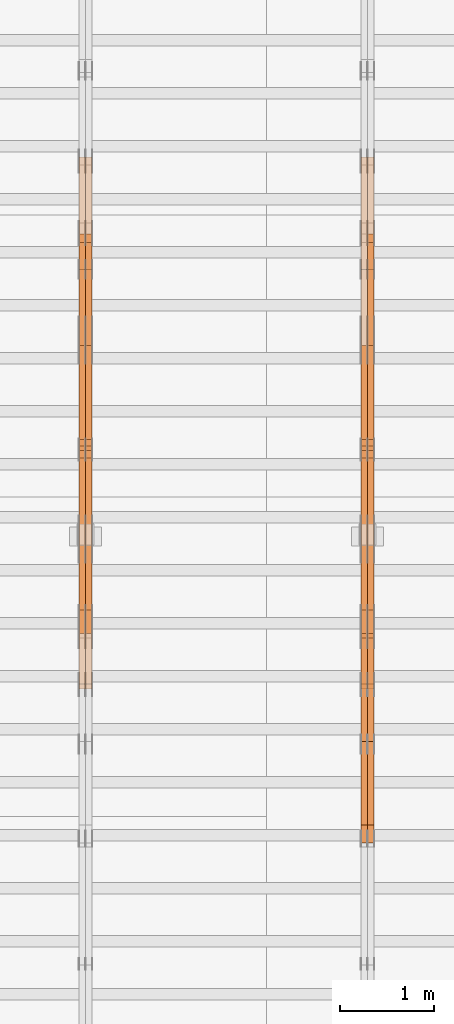
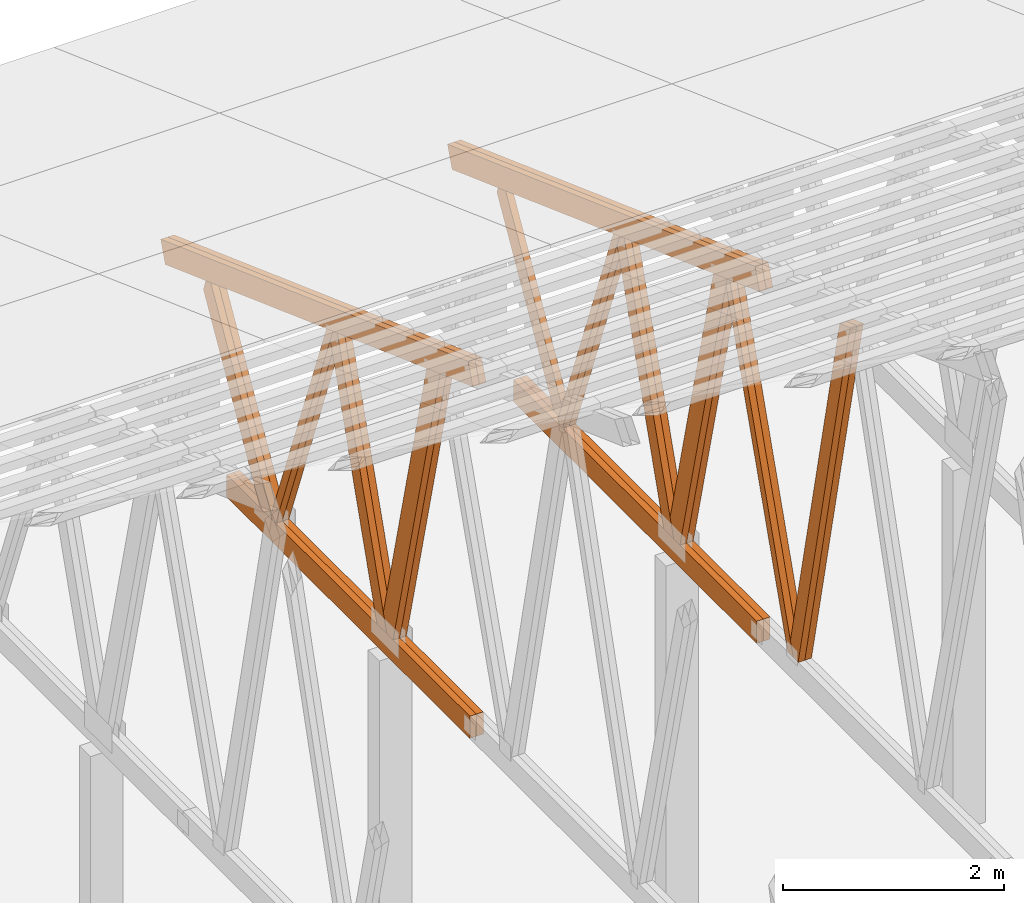
# One storey, part 58 of 189: 27 proxies.
"""IFC2X3 building model written with IfcOpenShell, lengths in millimetres."""

import ifcopenshell
import ifcopenshell.guid

model = None  # the IFC model being written
_history = None  # IfcOwnerHistory: only IFC2X3 demands one
_inside = {}  # id of a spatial element -> (the spatial element, [elements in it])
_under = {}  # id of a project, library or spatial element -> (it, [spatial elements below it])
_declared = {}  # id of a project -> (the project, [libraries it declares])
_typed = {}  # id of a type object -> (the type object, [elements of that type])
_made_of = {}  # id of a material, layer set ... -> (it, [elements and type objects made of it])


def new_model(schema):
    """Start an empty IFC model of exactly this schema.

    Asked for "IFC4X3", IfcOpenShell would pick the latest addendum, in which some entities
    have other attributes; the version numbers below select the first issue.
    IFC2X3 requires an IfcOwnerHistory on every rooted entity: one is made here for all.
    """
    global model, _history
    if schema == "IFC4X3":
        model = ifcopenshell.file(schema_version=(4, 3, 0, 0))
    else:
        model = ifcopenshell.file(schema=schema)
    _inside.clear()
    _under.clear()
    _declared.clear()
    _typed.clear()
    _made_of.clear()
    _history = None
    if model.schema == "IFC2X3":
        org = make("IfcOrganization", Name="unknown")
        user = make(
            "IfcPersonAndOrganization",
            ThePerson=make("IfcPerson", FamilyName="unknown"),
            TheOrganization=org,
        )
        app = make(
            "IfcApplication",
            ApplicationDeveloper=org,
            Version="unknown",
            ApplicationFullName="unknown",
            ApplicationIdentifier="unknown",
        )
        _history = make(
            "IfcOwnerHistory",
            OwningUser=user,
            OwningApplication=app,
            ChangeAction="ADDED",
            CreationDate=0,
        )
    return model


def make(cls, **values):
    """One entity of the class cls with the attributes given. An attribute that is None is left unset."""
    return model.create_entity(
        cls, **{name: value for name, value in values.items() if value is not None}
    )


def entity(cls, *values):
    """Any entity or typed value of the class cls, its attributes in the order of the schema. None: left unset."""
    e = model.create_entity(cls)
    for i, value in enumerate(values):
        if value is not None:
            e[i] = value
    return e


def rooted(cls, **values):
    """An entity with a GlobalId (a new one), such as an element, a storey or a relation."""
    return make(cls, GlobalId=ifcopenshell.guid.new(), OwnerHistory=_history, **values)


def si_unit(unit_type, name, prefix=None):
    """IfcSIUnit, for example si_unit("LENGTHUNIT", "METRE", prefix="MILLI")."""
    return make("IfcSIUnit", UnitType=unit_type, Prefix=prefix, Name=name)


def converted_unit(unit_type, name, factor, base, dimensions=None, offset=None):
    """IfcConversionBasedUnit, such as the inch: factor (a typed value) times the base unit."""
    return make(
        "IfcConversionBasedUnit"
        if offset is None
        else "IfcConversionBasedUnitWithOffset",
        ConversionOffset=offset,
        Dimensions=None
        if dimensions is None
        else entity("IfcDimensionalExponents", *dimensions),
        UnitType=unit_type,
        Name=name,
        ConversionFactor=make(
            "IfcMeasureWithUnit", ValueComponent=factor, UnitComponent=base
        ),
    )


def derived_unit(unit_type, elements):
    """IfcDerivedUnit: a product of units, each with its exponent."""
    return make(
        "IfcDerivedUnit",
        Elements=[
            make("IfcDerivedUnitElement", Unit=unit, Exponent=power)
            for unit, power in elements
        ],
        UnitType=unit_type,
    )


def assignment(units):
    """IfcUnitAssignment: the units of a project."""
    return None if units is None else make("IfcUnitAssignment", Units=units)


def point(xyz):
    """IfcCartesianPoint."""
    return None if xyz is None else make("IfcCartesianPoint", Coordinates=xyz)


def direction(xyz):
    """IfcDirection."""
    return None if xyz is None else make("IfcDirection", DirectionRatios=xyz)


def frame(location, z_axis=None, x_axis=None):
    """IfcAxis2Placement3D, a coordinate frame: its origin and axes. An axis left out is left unset."""
    return make(
        "IfcAxis2Placement3D",
        Location=point(location),
        Axis=direction(z_axis),
        RefDirection=direction(x_axis),
    )


def frame_2d(location, x_axis=None):
    """IfcAxis2Placement2D, a coordinate frame in the plane: its origin and x axis."""
    return make(
        "IfcAxis2Placement2D", Location=point(location), RefDirection=direction(x_axis)
    )


def origin():
    """The frame at (0, 0, 0) with its axes left unset."""
    return frame((0.0, 0.0, 0.0))


def origin_2d_with_axis():
    """The frame at (0, 0) in the plane with the x axis (1, 0) written out."""
    return frame_2d((0.0, 0.0), x_axis=(1.0, 0.0))


def place(relative_to, where):
    """IfcLocalPlacement: puts the frame where relative to a parent placement (None: the world)."""
    return make(
        "IfcLocalPlacement", PlacementRelTo=relative_to, RelativePlacement=where
    )


def context(
    kind, dimensions, precision=None, world=None, true_north=None, identifier=None
):
    """IfcGeometricRepresentationContext, for example the 3D "Model" context."""
    return make(
        "IfcGeometricRepresentationContext",
        ContextIdentifier=identifier,
        ContextType=kind,
        CoordinateSpaceDimension=dimensions,
        Precision=precision,
        WorldCoordinateSystem=world,
        TrueNorth=true_north,
    )


def subcontext(parent, identifier, kind, view, scale=None):
    """IfcGeometricRepresentationSubContext, for example "Body" below "Model"."""
    return make(
        "IfcGeometricRepresentationSubContext",
        ContextIdentifier=identifier,
        ContextType=kind,
        ParentContext=parent,
        TargetScale=scale,
        TargetView=view,
    )


def project(units=None, contexts=None):
    """IfcProject with its units and contexts."""
    return rooted(
        "IfcProject",
        Name="project",
        RepresentationContexts=contexts,
        UnitsInContext=assignment(units),
    )


def spatial(cls, under=None, at=None, **own):
    """A site, building, storey or space (cls), placed at a placement, below another one or the project."""
    s = rooted(cls, ObjectPlacement=at, **own)
    if under is not None:
        _under.setdefault(under.id(), (under, []))[1].append(s)
    return s


def polyline(points):
    """IfcPolyline through the points."""
    return make("IfcPolyline", Points=[point(p) for p in points])


def profile(cls, at=None, kind="AREA", **sizes):
    """A parametric profile (cls). Its sizes go by their IFC names, for example OverallWidth=200.0."""
    return make(cls, ProfileType=kind, Position=at, **sizes)


def rectangle(**sizes):
    """IfcRectangleProfileDef."""
    return profile("IfcRectangleProfileDef", **sizes)


def outline(outer, holes=None, kind="AREA"):
    """IfcArbitraryClosedProfileDef: a profile drawn as a closed curve; with holes, ...WithVoids."""
    if holes is None:
        return make("IfcArbitraryClosedProfileDef", ProfileType=kind, OuterCurve=outer)
    return make(
        "IfcArbitraryProfileDefWithVoids",
        ProfileType=kind,
        OuterCurve=outer,
        InnerCurves=holes,
    )


def extrude(swept, where, along, depth):
    """IfcExtrudedAreaSolid: the profile swept, set in the frame where, extruded along a direction by depth."""
    return make(
        "IfcExtrudedAreaSolid",
        SweptArea=swept,
        Position=where,
        ExtrudedDirection=direction(along),
        Depth=depth,
    )


def shape(context_of_items, identifier, shape_type, items):
    """IfcShapeRepresentation: the items that make up one representation, for example the "Body"."""
    return make(
        "IfcShapeRepresentation",
        ContextOfItems=context_of_items,
        RepresentationIdentifier=identifier,
        RepresentationType=shape_type,
        Items=items,
    )


def source(mapping_origin, context_of_items, identifier, shape_type, items):
    """IfcRepresentationMap: a shape defined once, which mapped items show again and again."""
    return make(
        "IfcRepresentationMap",
        MappingOrigin=mapping_origin,
        MappedRepresentation=shape(context_of_items, identifier, shape_type, items),
    )


def transform(
    local_origin,
    x_axis=None,
    y_axis=None,
    z_axis=None,
    scale=None,
    scale2=None,
    scale3=None,
    uniform=True,
):
    """IfcCartesianTransformationOperator3D, or its non-uniform kind. x_axis, y_axis, z_axis: its Axis1, 2, 3."""
    if uniform:
        return make(
            "IfcCartesianTransformationOperator3D",
            Axis1=direction(x_axis),
            Axis2=direction(y_axis),
            LocalOrigin=point(local_origin),
            Scale=scale,
            Axis3=direction(z_axis),
        )
    return make(
        "IfcCartesianTransformationOperator3DnonUniform",
        Axis1=direction(x_axis),
        Axis2=direction(y_axis),
        LocalOrigin=point(local_origin),
        Scale=scale,
        Axis3=direction(z_axis),
        Scale2=scale2,
        Scale3=scale3,
    )


def mapped(mapping_source, mapping_target):
    """IfcMappedItem: shows the shape of a source again, moved by a transform."""
    return make(
        "IfcMappedItem", MappingSource=mapping_source, MappingTarget=mapping_target
    )


def material(Name=None, Category=None):
    """IfcMaterial."""
    return make("IfcMaterial", Name=Name, Category=Category)


def made_of(thing, what):
    """Note that an element or type object is made of a material, layer set ...; save() writes the relation."""
    if what is not None:
        _made_of.setdefault(what.id(), (what, []))[1].append(thing)
    return thing


def type_object(cls, material=None, **own):
    """A type object (cls), such as IfcWallType, which elements share."""
    return made_of(rooted(cls, **own), material)


def type_shapes(of_type, sources):
    """Give a type object the sources (RepresentationMaps) that its elements show as mapped items."""
    of_type.RepresentationMaps = sources


def element(
    cls,
    number,
    at=None,
    inside=None,
    cuts=None,
    type_object=None,
    material=None,
    context=None,
    identifier="Body",
    shape_type=None,
    held_by="IfcProductDefinitionShape",
    body=None,
    shapes=None,
    **own,
):
    """One element of the class cls, such as IfcWall. Its Tag is "e" and its number.

    at: its placement. inside: the storey or other place that contains it. cuts: it is an
    opening in that element (IfcRelVoidsElement). A single representation is given by context,
    identifier, shape_type and body (its items); several are given by shapes. held_by: the class
    of the entity that holds the representations. save() writes the other relations.
    """
    e = rooted(cls, Tag="e%d" % number, ObjectPlacement=at, **own)
    if body is not None:
        shapes = [shape(context, identifier, shape_type, body)]
    if shapes is not None:
        e.Representation = make(held_by, Representations=shapes)
    if inside is not None:
        _inside.setdefault(inside.id(), (inside, []))[1].append(e)
    if cuts is not None:
        rooted(
            "IfcRelVoidsElement", RelatingBuildingElement=cuts, RelatedOpeningElement=e
        )
    if type_object is not None:
        _typed.setdefault(type_object.id(), (type_object, []))[1].append(e)
    return made_of(e, material)


def aggregate(whole, parts):
    """IfcRelAggregates: a whole, such as a stair, and the parts it consists of."""
    return rooted("IfcRelAggregates", RelatingObject=whole, RelatedObjects=parts)


def save(model, path):
    """Write the relations noted so far, then the file.

    IfcRelAggregates (storeys below a building ...), IfcRelContainedInSpatialStructure (elements
    in a storey), IfcRelDefinesByType, IfcRelAssociatesMaterial and IfcRelDeclares: one each for
    every whole, place, type object, material and project.
    """
    for whole, parts in _under.values():
        aggregate(whole, parts)
    for where, things in _inside.values():
        rooted(
            "IfcRelContainedInSpatialStructure",
            RelatedElements=things,
            RelatingStructure=where,
        )
    for kind, things in _typed.values():
        rooted("IfcRelDefinesByType", RelatedObjects=things, RelatingType=kind)
    for what, things in _made_of.values():
        rooted("IfcRelAssociatesMaterial", RelatedObjects=things, RelatingMaterial=what)
    for by, libraries in _declared.values():
        rooted("IfcRelDeclares", RelatingContext=by, RelatedDefinitions=libraries)
    model.write(path)


model = new_model("IFC2X3")

# Units and contexts
model_context = context("Model", 3, precision=0.01, world=origin(), true_north=direction((6.12303176911189e-17, 1.0)))
body_context = subcontext(model_context, "Body", "Model", "MODEL_VIEW")
ifc_project = project(units=[si_unit("LENGTHUNIT", "METRE", prefix="MILLI"), si_unit("AREAUNIT", "SQUARE_METRE"), si_unit("VOLUMEUNIT", "CUBIC_METRE"), converted_unit("PLANEANGLEUNIT", "DEGREE", entity("IfcRatioMeasure", 0.0174532925199433), si_unit("PLANEANGLEUNIT", "RADIAN"), dimensions=[0, 0, 0, 0, 0, 0, 0]), si_unit("MASSUNIT", "GRAM", prefix="KILO"), derived_unit("MASSDENSITYUNIT", [(si_unit("MASSUNIT", "GRAM", prefix="KILO"), 1), (si_unit("LENGTHUNIT", "METRE"), -3)]), si_unit("TIMEUNIT", "SECOND"), si_unit("FREQUENCYUNIT", "HERTZ"), si_unit("THERMODYNAMICTEMPERATUREUNIT", "DEGREE_CELSIUS"), derived_unit("THERMALTRANSMITTANCEUNIT", [(si_unit("MASSUNIT", "GRAM", prefix="KILO"), 1), (si_unit("THERMODYNAMICTEMPERATUREUNIT", "KELVIN"), -1), (si_unit("TIMEUNIT", "SECOND"), -3)]), derived_unit("VOLUMETRICFLOWRATEUNIT", [(si_unit("LENGTHUNIT", "METRE"), 3), (si_unit("TIMEUNIT", "SECOND"), -1)]), si_unit("ELECTRICCURRENTUNIT", "AMPERE"), si_unit("ELECTRICVOLTAGEUNIT", "VOLT"), si_unit("POWERUNIT", "WATT"), si_unit("FORCEUNIT", "NEWTON"), si_unit("ILLUMINANCEUNIT", "LUX"), si_unit("LUMINOUSFLUXUNIT", "LUMEN"), si_unit("LUMINOUSINTENSITYUNIT", "CANDELA"), derived_unit("USERDEFINED", [(si_unit("MASSUNIT", "GRAM", prefix="KILO"), -1), (si_unit("LENGTHUNIT", "METRE"), -2), (si_unit("TIMEUNIT", "SECOND"), 3), (si_unit("LUMINOUSFLUXUNIT", "LUMEN"), 1)]), derived_unit("LINEARVELOCITYUNIT", [(si_unit("LENGTHUNIT", "METRE"), 1), (si_unit("TIMEUNIT", "SECOND"), -1)]), si_unit("PRESSUREUNIT", "PASCAL"), derived_unit("USERDEFINED", [(si_unit("LENGTHUNIT", "METRE"), -2), (si_unit("MASSUNIT", "GRAM", prefix="KILO"), 1), (si_unit("TIMEUNIT", "SECOND"), -2)])], contexts=[model_context])

# Site, building, storey
site_placement = place(None, origin())
site = spatial("IfcSite", under=ifc_project, at=site_placement, CompositionType="ELEMENT")
building_placement = place(site_placement, origin())
building = spatial("IfcBuilding", under=site, at=building_placement, CompositionType="ELEMENT")
storey_placement = place(building_placement, origin())
storey = spatial("IfcBuildingStorey", under=building, at=storey_placement, Name="Default", CompositionType="ELEMENT", Elevation=0.0)

# Proxies
ifc_material_1 = material(Name="IfcSurfaceStyle #194294")
building_element_proxy_type_1 = type_object("IfcBuildingElementProxyType", Name="T1-W3 194292", PredefinedType="NOTDEFINED", material=ifc_material_1)
shared_shape_1 = source(origin(), body_context, "Body", "SweptSolid", [
    extrude(outline(polyline([(-2517.58938959787, -85.0001104675026), (1625.445846867, -85.0001104675027), (1768.20563426494, 0.000209440697654673), (1749.48871563991, 85.0000057471538), (-2625.55080717397, 85.0000057471538), (-2517.58938959787, -85.0001104675026)])), frame((1768.2056683344, 85.0000547211315, 0.0), z_axis=(0.0, 0.0, 1.0), x_axis=(-1.0, 0.0, 0.0)), (0.0, 0.0, 1.0), 69.9999999999997),
])
type_shapes(building_element_proxy_type_1, [shared_shape_1])
proxy_1_placement = place(building_placement, frame((36300.0, 18415.3042863408, 226.720947016584), z_axis=(-1.0, 0.0, 0.0), x_axis=(0.0, -0.215047682154604, 0.976603550269982)))
element("IfcBuildingElementProxy", 1, at=proxy_1_placement, inside=storey, type_object=building_element_proxy_type_1, material=ifc_material_1, Name="T1-W3", context=body_context, shape_type="MappedRepresentation", body=[
    mapped(shared_shape_1, transform((0.0, 0.0, 0.0), scale=1.0)),
])
ifc_material_2 = material(Name="IfcSurfaceStyle #194228")
building_element_proxy_type_2 = type_object("IfcBuildingElementProxyType", Name="T1-W3 194226", PredefinedType="NOTDEFINED", material=ifc_material_2)
shared_shape_2 = source(origin(), body_context, "Body", "SweptSolid", [
    extrude(outline(polyline([(-2517.58938959787, -85.0001104675026), (1625.445846867, -85.0001104675027), (1768.20563426494, 0.000209440697654673), (1749.48871563991, 85.0000057471538), (-2625.55080717397, 85.0000057471538), (-2517.58938959787, -85.0001104675026)])), frame((1768.2056683344, 85.0000547211315, 0.0), z_axis=(0.0, 0.0, 1.0), x_axis=(-1.0, 0.0, 0.0)), (0.0, 0.0, 1.0), 69.9999999999997),
])
type_shapes(building_element_proxy_type_2, [shared_shape_2])
proxy_2_placement = place(building_placement, frame((36230.0, 18415.3042863408, 226.720947016584), z_axis=(-1.0, 0.0, 0.0), x_axis=(0.0, -0.215047682154604, 0.976603550269982)))
element("IfcBuildingElementProxy", 2, at=proxy_2_placement, inside=storey, type_object=building_element_proxy_type_2, material=ifc_material_2, Name="T1-W3", context=body_context, shape_type="MappedRepresentation", body=[
    mapped(shared_shape_2, transform((0.0, 0.0, 0.0), scale=1.0)),
])
ifc_material_3 = material(Name="IfcSurfaceStyle #194030")
building_element_proxy_type_3 = type_object("IfcBuildingElementProxyType", Name="T1-W7 194028", PredefinedType="NOTDEFINED", material=ifc_material_3)
shared_shape_3 = source(origin(), body_context, "Body", "SweptSolid", [
    extrude(outline(polyline([(-2189.6662270939, -47.5000140805343), (1475.30081553583, -47.5000140805343), (1473.93388518462, 0.00042343352179337), (1398.58463533215, 47.4998023637734), (-2158.15310895869, 47.4998023637734), (-2189.6662270939, -47.5000140805343)])), frame((1475.30081553583, 47.5004895824757, 0.0), z_axis=(0.0, 0.0, 1.0), x_axis=(-1.0, 0.0, 0.0)), (0.0, 0.0, 1.0), 69.9999999999998),
])
type_shapes(building_element_proxy_type_3, [shared_shape_3])
proxy_3_placement = place(building_placement, frame((36300.0, 19742.3819153401, 3693.66743808885), z_axis=(-1.0, 0.0, 0.0), x_axis=(0.0, -0.314845237923104, -0.949143021971475)))
element("IfcBuildingElementProxy", 3, at=proxy_3_placement, inside=storey, type_object=building_element_proxy_type_3, material=ifc_material_3, Name="T1-W7", context=body_context, shape_type="MappedRepresentation", body=[
    mapped(shared_shape_3, transform((0.0, 0.0, 0.0), scale=1.0)),
])
ifc_material_4 = material(Name="IfcSurfaceStyle #193964")
building_element_proxy_type_4 = type_object("IfcBuildingElementProxyType", Name="T1-W7 193962", PredefinedType="NOTDEFINED", material=ifc_material_4)
shared_shape_4 = source(origin(), body_context, "Body", "SweptSolid", [
    extrude(outline(polyline([(-2189.6662270939, -47.5000140805343), (1475.30081553583, -47.5000140805343), (1473.93388518462, 0.00042343352179337), (1398.58463533215, 47.4998023637734), (-2158.15310895869, 47.4998023637734), (-2189.6662270939, -47.5000140805343)])), frame((1475.30081553583, 47.5004895824757, 0.0), z_axis=(0.0, 0.0, 1.0), x_axis=(-1.0, 0.0, 0.0)), (0.0, 0.0, 1.0), 69.9999999999998),
])
type_shapes(building_element_proxy_type_4, [shared_shape_4])
proxy_4_placement = place(building_placement, frame((36230.0, 19742.3819153401, 3693.66743808885), z_axis=(-1.0, 0.0, 0.0), x_axis=(0.0, -0.314845237923104, -0.949143021971475)))
element("IfcBuildingElementProxy", 4, at=proxy_4_placement, inside=storey, type_object=building_element_proxy_type_4, material=ifc_material_4, Name="T1-W7", context=body_context, shape_type="MappedRepresentation", body=[
    mapped(shared_shape_4, transform((0.0, 0.0, 0.0), scale=1.0)),
])
ifc_material_5 = material(Name="IfcSurfaceStyle #193766")
building_element_proxy_type_5 = type_object("IfcBuildingElementProxyType", Name="T1-W1 193764", PredefinedType="NOTDEFINED", material=ifc_material_5)
shared_shape_5 = source(origin(), body_context, "Body", "SweptSolid", [
    extrude(outline(polyline([(-1996.99427801396, -109.999889649051), (1271.09905152223, -109.999889649051), (1448.88120817726, -0.000113190727324008), (1421.70802776002, 109.999946244415), (-2144.69400944554, 109.999946244415), (-1996.99427801396, -109.999889649051)])), frame((1448.88120817726, 110.000265670598, 0.0), z_axis=(0.0, 0.0, 1.0), x_axis=(-1.0, 0.0, 0.0)), (0.0, 0.0, 1.0), 69.9999999999998),
])
type_shapes(building_element_proxy_type_5, [shared_shape_5])
proxy_5_placement = place(building_placement, frame((36300.0, 20558.6774904859, 218.61972674968), z_axis=(-1.0, 0.0, 0.0), x_axis=(0.0, -0.239819839925979, 0.970817410421691)))
element("IfcBuildingElementProxy", 5, at=proxy_5_placement, inside=storey, type_object=building_element_proxy_type_5, material=ifc_material_5, Name="T1-W1", context=body_context, shape_type="MappedRepresentation", body=[
    mapped(shared_shape_5, transform((0.0, 0.0, 0.0), scale=1.0)),
])
ifc_material_6 = material(Name="IfcSurfaceStyle #193700")
building_element_proxy_type_6 = type_object("IfcBuildingElementProxyType", Name="T1-W1 193698", PredefinedType="NOTDEFINED", material=ifc_material_6)
shared_shape_6 = source(origin(), body_context, "Body", "SweptSolid", [
    extrude(outline(polyline([(-1996.99427801396, -109.999889649051), (1271.09905152223, -109.999889649051), (1448.88120817726, -0.000113190727324008), (1421.70802776002, 109.999946244415), (-2144.69400944554, 109.999946244415), (-1996.99427801396, -109.999889649051)])), frame((1448.88120817726, 110.000265670598, 0.0), z_axis=(0.0, 0.0, 1.0), x_axis=(-1.0, 0.0, 0.0)), (0.0, 0.0, 1.0), 69.9999999999998),
])
type_shapes(building_element_proxy_type_6, [shared_shape_6])
proxy_6_placement = place(building_placement, frame((36230.0, 20558.6774904859, 218.61972674968), z_axis=(-1.0, 0.0, 0.0), x_axis=(0.0, -0.239819839925979, 0.970817410421691)))
element("IfcBuildingElementProxy", 6, at=proxy_6_placement, inside=storey, type_object=building_element_proxy_type_6, material=ifc_material_6, Name="T1-W1", context=body_context, shape_type="MappedRepresentation", body=[
    mapped(shared_shape_6, transform((0.0, 0.0, 0.0), scale=1.0)),
])
ifc_material_7 = material(Name="IfcSurfaceStyle #193502")
building_element_proxy_type_7 = type_object("IfcBuildingElementProxyType", Name="T1-W4 193500", PredefinedType="NOTDEFINED", material=ifc_material_7)
shared_shape_7 = source(origin(), body_context, "Body", "SweptSolid", [
    extrude(outline(polyline([(-1742.90513395849, -84.9997422414737), (1181.3544167489, -84.9997422414737), (1178.19398821251, -0.000208932978430543), (1071.44989130457, 84.999846707963), (-1688.09316230749, 84.999846707963), (-1742.90513395849, -84.9997422414737)])), frame((1181.35452116422, 84.999886337523, 0.0), z_axis=(0.0, 0.0, 1.0), x_axis=(-1.0, 0.0, 0.0)), (0.0, 0.0, 1.0), 69.9999999999998),
])
type_shapes(building_element_proxy_type_7, [shared_shape_7])
proxy_7_placement = place(building_placement, frame((36300.0, 21724.6281517871, 2976.00232464744), z_axis=(-1.0, 0.0, 0.0), x_axis=(0.0, -0.306868406216495, -0.951751953644514)))
element("IfcBuildingElementProxy", 7, at=proxy_7_placement, inside=storey, type_object=building_element_proxy_type_7, material=ifc_material_7, Name="T1-W4", context=body_context, shape_type="MappedRepresentation", body=[
    mapped(shared_shape_7, transform((0.0, 0.0, 0.0), scale=1.0)),
])
ifc_material_8 = material(Name="IfcSurfaceStyle #193436")
building_element_proxy_type_8 = type_object("IfcBuildingElementProxyType", Name="T1-W4 193434", PredefinedType="NOTDEFINED", material=ifc_material_8)
shared_shape_8 = source(origin(), body_context, "Body", "SweptSolid", [
    extrude(outline(polyline([(-1742.90513395849, -84.9997422414737), (1181.3544167489, -84.9997422414737), (1178.19398821251, -0.000208932978430543), (1071.44989130457, 84.999846707963), (-1688.09316230749, 84.999846707963), (-1742.90513395849, -84.9997422414737)])), frame((1181.35452116422, 84.999886337523, 0.0), z_axis=(0.0, 0.0, 1.0), x_axis=(-1.0, 0.0, 0.0)), (0.0, 0.0, 1.0), 69.9999999999998),
])
type_shapes(building_element_proxy_type_8, [shared_shape_8])
proxy_8_placement = place(building_placement, frame((36230.0, 21724.6281517871, 2976.00232464744), z_axis=(-1.0, 0.0, 0.0), x_axis=(0.0, -0.306868406216495, -0.951751953644514)))
element("IfcBuildingElementProxy", 8, at=proxy_8_placement, inside=storey, type_object=building_element_proxy_type_8, material=ifc_material_8, Name="T1-W4", context=body_context, shape_type="MappedRepresentation", body=[
    mapped(shared_shape_8, transform((0.0, 0.0, 0.0), scale=1.0)),
])
ifc_material_9 = material(Name="IfcSurfaceStyle #193238")
building_element_proxy_type_9 = type_object("IfcBuildingElementProxyType", Name="T1-W8 193236", PredefinedType="NOTDEFINED", material=ifc_material_9)
shared_shape_9 = source(origin(), body_context, "Body", "SweptSolid", [
    extrude(outline(polyline([(-1700.10906247918, -47.4998559987011), (1140.60243146647, -47.4998559987011), (1179.56122089033, 0.000120838919977206), (1161.65086478184, 47.4997955792411), (-1781.70545465947, 47.4997955792411), (-1700.10906247918, -47.4998559987011)])), frame((1179.56128464708, 47.5000634692093, 0.0), z_axis=(0.0, 0.0, 1.0), x_axis=(-1.0, 0.0, 0.0)), (0.0, 0.0, 1.0), 69.9999999999998),
])
type_shapes(building_element_proxy_type_9, [shared_shape_9])
proxy_9_placement = place(building_placement, frame((36300.0, 22687.5385403115, 228.241249073207), z_axis=(-1.0, 0.0, 0.0), x_axis=(0.0, -0.352814979177604, 0.93569310698963)))
element("IfcBuildingElementProxy", 9, at=proxy_9_placement, inside=storey, type_object=building_element_proxy_type_9, material=ifc_material_9, Name="T1-W8", context=body_context, shape_type="MappedRepresentation", body=[
    mapped(shared_shape_9, transform((0.0, 0.0, 0.0), scale=1.0)),
])
ifc_material_10 = material(Name="IfcSurfaceStyle #193172")
building_element_proxy_type_10 = type_object("IfcBuildingElementProxyType", Name="T1-W8 193170", PredefinedType="NOTDEFINED", material=ifc_material_10)
shared_shape_10 = source(origin(), body_context, "Body", "SweptSolid", [
    extrude(outline(polyline([(-1700.10906247918, -47.4998559987011), (1140.60243146647, -47.4998559987011), (1179.56122089033, 0.000120838919977206), (1161.65086478184, 47.4997955792411), (-1781.70545465947, 47.4997955792411), (-1700.10906247918, -47.4998559987011)])), frame((1179.56128464708, 47.5000634692093, 0.0), z_axis=(0.0, 0.0, 1.0), x_axis=(-1.0, 0.0, 0.0)), (0.0, 0.0, 1.0), 69.9999999999998),
])
type_shapes(building_element_proxy_type_10, [shared_shape_10])
proxy_10_placement = place(building_placement, frame((36230.0, 22687.5385403115, 228.241249073207), z_axis=(-1.0, 0.0, 0.0), x_axis=(0.0, -0.352814979177604, 0.93569310698963)))
element("IfcBuildingElementProxy", 10, at=proxy_10_placement, inside=storey, type_object=building_element_proxy_type_10, material=ifc_material_10, Name="T1-W8", context=body_context, shape_type="MappedRepresentation", body=[
    mapped(shared_shape_10, transform((0.0, 0.0, 0.0), scale=1.0)),
])
ifc_material_11 = material(Name="IfcSurfaceStyle #192974")
building_element_proxy_type_11 = type_object("IfcBuildingElementProxyType", Name="T1-W2 192972", PredefinedType="NOTDEFINED", material=ifc_material_11)
shared_shape_11 = source(origin(), body_context, "Body", "SweptSolid", [
    extrude(outline(polyline([(-1361.89144606429, -97.5000598486876), (887.613245225805, -97.5000598486876), (904.774262962339, 0.000302345139042259), (818.892339969004, 97.4999086761182), (-1249.38840209286, 97.4999086761182), (-1361.89144606429, -97.5000598486876)])), frame((904.774262962339, 97.5000966763391, 0.0), z_axis=(0.0, 0.0, 1.0), x_axis=(-1.0, 0.0, 0.0)), (0.0, 0.0, 1.0), 69.9999999999999),
])
type_shapes(building_element_proxy_type_11, [shared_shape_11])
proxy_11_placement = place(building_placement, frame((36300.0, 24033.6159173732, 2110.89189244614), z_axis=(-1.0, 0.0, 0.0), x_axis=(0.0, -0.5, -0.866025403784439)))
element("IfcBuildingElementProxy", 11, at=proxy_11_placement, inside=storey, type_object=building_element_proxy_type_11, material=ifc_material_11, Name="T1-W2", context=body_context, shape_type="MappedRepresentation", body=[
    mapped(shared_shape_11, transform((0.0, 0.0, 0.0), scale=1.0)),
])
ifc_material_12 = material(Name="IfcSurfaceStyle #190898")
building_element_proxy_type_12 = type_object("IfcBuildingElementProxyType", Name="T1-B4 190896", PredefinedType="NOTDEFINED", material=ifc_material_12)
shared_shape_12 = source(origin(), body_context, "Body", "SweptSolid", [
    extrude(rectangle(XDim=4408.2412109375, YDim=245.000000000001, at=origin_2d_with_axis()), frame((2204.12060546875, 122.5, 0.0), z_axis=(0.0, 0.0, 1.0), x_axis=(-1.0, 0.0, 0.0)), (0.0, 0.0, 1.0), 69.9999999999997),
])
type_shapes(building_element_proxy_type_12, [shared_shape_12])
proxy_12_placement = place(building_placement, frame((36300.0, 19161.7587890625, 245.0), z_axis=(-1.0, 0.0, 0.0), x_axis=(0.0, 1.0, 0.0)))
element("IfcBuildingElementProxy", 12, at=proxy_12_placement, inside=storey, type_object=building_element_proxy_type_12, material=ifc_material_12, Name="T1-B4", context=body_context, shape_type="MappedRepresentation", body=[
    mapped(shared_shape_12, transform((0.0, 0.0, 0.0), scale=1.0)),
])
ifc_material_13 = material(Name="IfcSurfaceStyle #190841")
building_element_proxy_type_13 = type_object("IfcBuildingElementProxyType", Name="T1-B4 190839", PredefinedType="NOTDEFINED", material=ifc_material_13)
shared_shape_13 = source(origin(), body_context, "Body", "SweptSolid", [
    extrude(rectangle(XDim=4408.2412109375, YDim=245.000000000001, at=origin_2d_with_axis()), frame((2204.12060546875, 122.5, 0.0), z_axis=(0.0, 0.0, 1.0), x_axis=(-1.0, 0.0, 0.0)), (0.0, 0.0, 1.0), 69.9999999999997),
])
type_shapes(building_element_proxy_type_13, [shared_shape_13])
proxy_13_placement = place(building_placement, frame((36230.0, 19161.7587890625, 245.0), z_axis=(-1.0, 0.0, 0.0), x_axis=(0.0, 1.0, 0.0)))
element("IfcBuildingElementProxy", 13, at=proxy_13_placement, inside=storey, type_object=building_element_proxy_type_13, material=ifc_material_13, Name="T1-B4", context=body_context, shape_type="MappedRepresentation", body=[
    mapped(shared_shape_13, transform((0.0, 0.0, 0.0), scale=1.0)),
])
ifc_material_14 = material(Name="IfcSurfaceStyle #189854")
building_element_proxy_type_14 = type_object("IfcBuildingElementProxyType", Name="T1-T1 189852", PredefinedType="NOTDEFINED", material=ifc_material_14)
shared_shape_14 = source(origin(), body_context, "Body", "SweptSolid", [
    extrude(outline(polyline([(-2964.99982426074, -122.499947708046), (2964.99981923522, -122.499947708046), (2964.99984513599, 122.499947708046), (-2964.99984011047, 122.499947708046), (-2964.99982426074, -122.499947708046)])), frame((2964.99984513599, 122.499998966405, 0.0), z_axis=(0.0, 0.0, 1.0), x_axis=(-1.0, 0.0, 0.0)), (0.0, 0.0, 1.0), 69.9999999999996),
])
type_shapes(building_element_proxy_type_14, [shared_shape_14])
proxy_14_placement = place(building_placement, frame((36300.0, 24681.3398262186, 1893.12531804384), z_axis=(-1.0, 0.0, 0.0), x_axis=(0.0, -0.939692620785908, 0.342020143325669)))
element("IfcBuildingElementProxy", 14, at=proxy_14_placement, inside=storey, type_object=building_element_proxy_type_14, material=ifc_material_14, Name="T1-T1", context=body_context, shape_type="MappedRepresentation", body=[
    mapped(shared_shape_14, transform((0.0, 0.0, 0.0), scale=1.0)),
])
ifc_material_15 = material(Name="IfcSurfaceStyle #189797")
building_element_proxy_type_15 = type_object("IfcBuildingElementProxyType", Name="T1-T1 189795", PredefinedType="NOTDEFINED", material=ifc_material_15)
shared_shape_15 = source(origin(), body_context, "Body", "SweptSolid", [
    extrude(outline(polyline([(-2964.99982426074, -122.499947708046), (2964.99981923522, -122.499947708046), (2964.99984513599, 122.499947708046), (-2964.99984011047, 122.499947708046), (-2964.99982426074, -122.499947708046)])), frame((2964.99984513599, 122.499998966405, 0.0), z_axis=(0.0, 0.0, 1.0), x_axis=(-1.0, 0.0, 0.0)), (0.0, 0.0, 1.0), 69.9999999999996),
])
type_shapes(building_element_proxy_type_15, [shared_shape_15])
proxy_15_placement = place(building_placement, frame((36230.0, 24681.3398262186, 1893.12531804384), z_axis=(-1.0, 0.0, 0.0), x_axis=(0.0, -0.939692620785908, 0.342020143325669)))
element("IfcBuildingElementProxy", 15, at=proxy_15_placement, inside=storey, type_object=building_element_proxy_type_15, material=ifc_material_15, Name="T1-T1", context=body_context, shape_type="MappedRepresentation", body=[
    mapped(shared_shape_15, transform((0.0, 0.0, 0.0), scale=1.0)),
])
ifc_material_16 = material(Name="IfcSurfaceStyle #177976")
building_element_proxy_type_16 = type_object("IfcBuildingElementProxyType", Name="T1-W1 177974", PredefinedType="NOTDEFINED", material=ifc_material_16)
shared_shape_16 = source(origin(), body_context, "Body", "SweptSolid", [
    extrude(outline(polyline([(-1996.99427801396, -109.999889649051), (1271.09905152223, -109.999889649051), (1448.88120817726, -0.000113190727324008), (1421.70802776002, 109.999946244415), (-2144.69400944554, 109.999946244415), (-1996.99427801396, -109.999889649051)])), frame((1448.88120817726, 110.000265670598, 0.0), z_axis=(0.0, 0.0, 1.0), x_axis=(-1.0, 0.0, 0.0)), (0.0, 0.0, 1.0), 69.9999999999998),
])
type_shapes(building_element_proxy_type_16, [shared_shape_16])
proxy_16_placement = place(building_placement, frame((33300.0, 20558.6774904859, 218.61972674968), z_axis=(-1.0, 0.0, 0.0), x_axis=(0.0, -0.239819839925979, 0.970817410421691)))
element("IfcBuildingElementProxy", 16, at=proxy_16_placement, inside=storey, type_object=building_element_proxy_type_16, material=ifc_material_16, Name="T1-W1", context=body_context, shape_type="MappedRepresentation", body=[
    mapped(shared_shape_16, transform((0.0, 0.0, 0.0), scale=1.0)),
])
ifc_material_17 = material(Name="IfcSurfaceStyle #177910")
building_element_proxy_type_17 = type_object("IfcBuildingElementProxyType", Name="T1-W1 177908", PredefinedType="NOTDEFINED", material=ifc_material_17)
shared_shape_17 = source(origin(), body_context, "Body", "SweptSolid", [
    extrude(outline(polyline([(-1996.99427801396, -109.999889649051), (1271.09905152223, -109.999889649051), (1448.88120817726, -0.000113190727324008), (1421.70802776002, 109.999946244415), (-2144.69400944554, 109.999946244415), (-1996.99427801396, -109.999889649051)])), frame((1448.88120817726, 110.000265670598, 0.0), z_axis=(0.0, 0.0, 1.0), x_axis=(-1.0, 0.0, 0.0)), (0.0, 0.0, 1.0), 69.9999999999998),
])
type_shapes(building_element_proxy_type_17, [shared_shape_17])
proxy_17_placement = place(building_placement, frame((33230.0, 20558.6774904859, 218.61972674968), z_axis=(-1.0, 0.0, 0.0), x_axis=(0.0, -0.239819839925979, 0.970817410421691)))
element("IfcBuildingElementProxy", 17, at=proxy_17_placement, inside=storey, type_object=building_element_proxy_type_17, material=ifc_material_17, Name="T1-W1", context=body_context, shape_type="MappedRepresentation", body=[
    mapped(shared_shape_17, transform((0.0, 0.0, 0.0), scale=1.0)),
])
ifc_material_18 = material(Name="IfcSurfaceStyle #177712")
building_element_proxy_type_18 = type_object("IfcBuildingElementProxyType", Name="T1-W4 177710", PredefinedType="NOTDEFINED", material=ifc_material_18)
shared_shape_18 = source(origin(), body_context, "Body", "SweptSolid", [
    extrude(outline(polyline([(-1742.90513395849, -84.9997422414737), (1181.3544167489, -84.9997422414737), (1178.19398821251, -0.000208932978430543), (1071.44989130457, 84.999846707963), (-1688.09316230749, 84.999846707963), (-1742.90513395849, -84.9997422414737)])), frame((1181.35452116422, 84.999886337523, 0.0), z_axis=(0.0, 0.0, 1.0), x_axis=(-1.0, 0.0, 0.0)), (0.0, 0.0, 1.0), 69.9999999999998),
])
type_shapes(building_element_proxy_type_18, [shared_shape_18])
proxy_18_placement = place(building_placement, frame((33300.0, 21724.6281517871, 2976.00232464744), z_axis=(-1.0, 0.0, 0.0), x_axis=(0.0, -0.306868406216495, -0.951751953644514)))
element("IfcBuildingElementProxy", 18, at=proxy_18_placement, inside=storey, type_object=building_element_proxy_type_18, material=ifc_material_18, Name="T1-W4", context=body_context, shape_type="MappedRepresentation", body=[
    mapped(shared_shape_18, transform((0.0, 0.0, 0.0), scale=1.0)),
])
ifc_material_19 = material(Name="IfcSurfaceStyle #177646")
building_element_proxy_type_19 = type_object("IfcBuildingElementProxyType", Name="T1-W4 177644", PredefinedType="NOTDEFINED", material=ifc_material_19)
shared_shape_19 = source(origin(), body_context, "Body", "SweptSolid", [
    extrude(outline(polyline([(-1742.90513395849, -84.9997422414737), (1181.3544167489, -84.9997422414737), (1178.19398821251, -0.000208932978430543), (1071.44989130457, 84.999846707963), (-1688.09316230749, 84.999846707963), (-1742.90513395849, -84.9997422414737)])), frame((1181.35452116422, 84.999886337523, 0.0), z_axis=(0.0, 0.0, 1.0), x_axis=(-1.0, 0.0, 0.0)), (0.0, 0.0, 1.0), 69.9999999999998),
])
type_shapes(building_element_proxy_type_19, [shared_shape_19])
proxy_19_placement = place(building_placement, frame((33230.0, 21724.6281517871, 2976.00232464744), z_axis=(-1.0, 0.0, 0.0), x_axis=(0.0, -0.306868406216495, -0.951751953644514)))
element("IfcBuildingElementProxy", 19, at=proxy_19_placement, inside=storey, type_object=building_element_proxy_type_19, material=ifc_material_19, Name="T1-W4", context=body_context, shape_type="MappedRepresentation", body=[
    mapped(shared_shape_19, transform((0.0, 0.0, 0.0), scale=1.0)),
])
ifc_material_20 = material(Name="IfcSurfaceStyle #177448")
building_element_proxy_type_20 = type_object("IfcBuildingElementProxyType", Name="T1-W8 177446", PredefinedType="NOTDEFINED", material=ifc_material_20)
shared_shape_20 = source(origin(), body_context, "Body", "SweptSolid", [
    extrude(outline(polyline([(-1700.10906247918, -47.4998559987011), (1140.60243146647, -47.4998559987011), (1179.56122089033, 0.000120838919977206), (1161.65086478184, 47.4997955792411), (-1781.70545465947, 47.4997955792411), (-1700.10906247918, -47.4998559987011)])), frame((1179.56128464708, 47.5000634692093, 0.0), z_axis=(0.0, 0.0, 1.0), x_axis=(-1.0, 0.0, 0.0)), (0.0, 0.0, 1.0), 69.9999999999998),
])
type_shapes(building_element_proxy_type_20, [shared_shape_20])
proxy_20_placement = place(building_placement, frame((33300.0, 22687.5385403115, 228.241249073207), z_axis=(-1.0, 0.0, 0.0), x_axis=(0.0, -0.352814979177604, 0.93569310698963)))
element("IfcBuildingElementProxy", 20, at=proxy_20_placement, inside=storey, type_object=building_element_proxy_type_20, material=ifc_material_20, Name="T1-W8", context=body_context, shape_type="MappedRepresentation", body=[
    mapped(shared_shape_20, transform((0.0, 0.0, 0.0), scale=1.0)),
])
ifc_material_21 = material(Name="IfcSurfaceStyle #177382")
building_element_proxy_type_21 = type_object("IfcBuildingElementProxyType", Name="T1-W8 177380", PredefinedType="NOTDEFINED", material=ifc_material_21)
shared_shape_21 = source(origin(), body_context, "Body", "SweptSolid", [
    extrude(outline(polyline([(-1700.10906247918, -47.4998559987011), (1140.60243146647, -47.4998559987011), (1179.56122089033, 0.000120838919977206), (1161.65086478184, 47.4997955792411), (-1781.70545465947, 47.4997955792411), (-1700.10906247918, -47.4998559987011)])), frame((1179.56128464708, 47.5000634692093, 0.0), z_axis=(0.0, 0.0, 1.0), x_axis=(-1.0, 0.0, 0.0)), (0.0, 0.0, 1.0), 69.9999999999998),
])
type_shapes(building_element_proxy_type_21, [shared_shape_21])
proxy_21_placement = place(building_placement, frame((33230.0, 22687.5385403115, 228.241249073207), z_axis=(-1.0, 0.0, 0.0), x_axis=(0.0, -0.352814979177604, 0.93569310698963)))
element("IfcBuildingElementProxy", 21, at=proxy_21_placement, inside=storey, type_object=building_element_proxy_type_21, material=ifc_material_21, Name="T1-W8", context=body_context, shape_type="MappedRepresentation", body=[
    mapped(shared_shape_21, transform((0.0, 0.0, 0.0), scale=1.0)),
])
ifc_material_22 = material(Name="IfcSurfaceStyle #177184")
building_element_proxy_type_22 = type_object("IfcBuildingElementProxyType", Name="T1-W2 177182", PredefinedType="NOTDEFINED", material=ifc_material_22)
shared_shape_22 = source(origin(), body_context, "Body", "SweptSolid", [
    extrude(outline(polyline([(-1361.89144606429, -97.5000598486876), (887.613245225805, -97.5000598486876), (904.774262962339, 0.000302345139042259), (818.892339969004, 97.4999086761182), (-1249.38840209286, 97.4999086761182), (-1361.89144606429, -97.5000598486876)])), frame((904.774262962339, 97.5000966763391, 0.0), z_axis=(0.0, 0.0, 1.0), x_axis=(-1.0, 0.0, 0.0)), (0.0, 0.0, 1.0), 69.9999999999999),
])
type_shapes(building_element_proxy_type_22, [shared_shape_22])
proxy_22_placement = place(building_placement, frame((33300.0, 24033.6159173732, 2110.89189244614), z_axis=(-1.0, 0.0, 0.0), x_axis=(0.0, -0.5, -0.866025403784439)))
element("IfcBuildingElementProxy", 22, at=proxy_22_placement, inside=storey, type_object=building_element_proxy_type_22, material=ifc_material_22, Name="T1-W2", context=body_context, shape_type="MappedRepresentation", body=[
    mapped(shared_shape_22, transform((0.0, 0.0, 0.0), scale=1.0)),
])
ifc_material_23 = material(Name="IfcSurfaceStyle #177118")
building_element_proxy_type_23 = type_object("IfcBuildingElementProxyType", Name="T1-W2 177116", PredefinedType="NOTDEFINED", material=ifc_material_23)
shared_shape_23 = source(origin(), body_context, "Body", "SweptSolid", [
    extrude(outline(polyline([(-1361.89144606429, -97.5000598486876), (887.613245225805, -97.5000598486876), (904.774262962339, 0.000302345139042259), (818.892339969004, 97.4999086761182), (-1249.38840209286, 97.4999086761182), (-1361.89144606429, -97.5000598486876)])), frame((904.774262962339, 97.5000966763391, 0.0), z_axis=(0.0, 0.0, 1.0), x_axis=(-1.0, 0.0, 0.0)), (0.0, 0.0, 1.0), 69.9999999999999),
])
type_shapes(building_element_proxy_type_23, [shared_shape_23])
proxy_23_placement = place(building_placement, frame((33230.0, 24033.6159173732, 2110.89189244614), z_axis=(-1.0, 0.0, 0.0), x_axis=(0.0, -0.5, -0.866025403784439)))
element("IfcBuildingElementProxy", 23, at=proxy_23_placement, inside=storey, type_object=building_element_proxy_type_23, material=ifc_material_23, Name="T1-W2", context=body_context, shape_type="MappedRepresentation", body=[
    mapped(shared_shape_23, transform((0.0, 0.0, 0.0), scale=1.0)),
])
ifc_material_24 = material(Name="IfcSurfaceStyle #175108")
building_element_proxy_type_24 = type_object("IfcBuildingElementProxyType", Name="T1-B4 175106", PredefinedType="NOTDEFINED", material=ifc_material_24)
shared_shape_24 = source(origin(), body_context, "Body", "SweptSolid", [
    extrude(rectangle(XDim=4408.2412109375, YDim=245.000000000001, at=origin_2d_with_axis()), frame((2204.12060546875, 122.5, 0.0), z_axis=(0.0, 0.0, 1.0), x_axis=(-1.0, 0.0, 0.0)), (0.0, 0.0, 1.0), 69.9999999999997),
])
type_shapes(building_element_proxy_type_24, [shared_shape_24])
proxy_24_placement = place(building_placement, frame((33300.0, 19161.7587890625, 245.0), z_axis=(-1.0, 0.0, 0.0), x_axis=(0.0, 1.0, 0.0)))
element("IfcBuildingElementProxy", 24, at=proxy_24_placement, inside=storey, type_object=building_element_proxy_type_24, material=ifc_material_24, Name="T1-B4", context=body_context, shape_type="MappedRepresentation", body=[
    mapped(shared_shape_24, transform((0.0, 0.0, 0.0), scale=1.0)),
])
ifc_material_25 = material(Name="IfcSurfaceStyle #175051")
building_element_proxy_type_25 = type_object("IfcBuildingElementProxyType", Name="T1-B4 175049", PredefinedType="NOTDEFINED", material=ifc_material_25)
shared_shape_25 = source(origin(), body_context, "Body", "SweptSolid", [
    extrude(rectangle(XDim=4408.2412109375, YDim=245.000000000001, at=origin_2d_with_axis()), frame((2204.12060546875, 122.5, 0.0), z_axis=(0.0, 0.0, 1.0), x_axis=(-1.0, 0.0, 0.0)), (0.0, 0.0, 1.0), 69.9999999999997),
])
type_shapes(building_element_proxy_type_25, [shared_shape_25])
proxy_25_placement = place(building_placement, frame((33230.0, 19161.7587890625, 245.0), z_axis=(-1.0, 0.0, 0.0), x_axis=(0.0, 1.0, 0.0)))
element("IfcBuildingElementProxy", 25, at=proxy_25_placement, inside=storey, type_object=building_element_proxy_type_25, material=ifc_material_25, Name="T1-B4", context=body_context, shape_type="MappedRepresentation", body=[
    mapped(shared_shape_25, transform((0.0, 0.0, 0.0), scale=1.0)),
])
ifc_material_26 = material(Name="IfcSurfaceStyle #174064")
building_element_proxy_type_26 = type_object("IfcBuildingElementProxyType", Name="T1-T1 174062", PredefinedType="NOTDEFINED", material=ifc_material_26)
shared_shape_26 = source(origin(), body_context, "Body", "SweptSolid", [
    extrude(outline(polyline([(-2964.99982426074, -122.499947708046), (2964.99981923522, -122.499947708046), (2964.99984513599, 122.499947708046), (-2964.99984011047, 122.499947708046), (-2964.99982426074, -122.499947708046)])), frame((2964.99984513599, 122.499998966405, 0.0), z_axis=(0.0, 0.0, 1.0), x_axis=(-1.0, 0.0, 0.0)), (0.0, 0.0, 1.0), 69.9999999999996),
])
type_shapes(building_element_proxy_type_26, [shared_shape_26])
proxy_26_placement = place(building_placement, frame((33300.0, 24681.3398262186, 1893.12531804384), z_axis=(-1.0, 0.0, 0.0), x_axis=(0.0, -0.939692620785908, 0.342020143325669)))
element("IfcBuildingElementProxy", 26, at=proxy_26_placement, inside=storey, type_object=building_element_proxy_type_26, material=ifc_material_26, Name="T1-T1", context=body_context, shape_type="MappedRepresentation", body=[
    mapped(shared_shape_26, transform((0.0, 0.0, 0.0), scale=1.0)),
])
ifc_material_27 = material(Name="IfcSurfaceStyle #174007")
building_element_proxy_type_27 = type_object("IfcBuildingElementProxyType", Name="T1-T1 174005", PredefinedType="NOTDEFINED", material=ifc_material_27)
shared_shape_27 = source(origin(), body_context, "Body", "SweptSolid", [
    extrude(outline(polyline([(-2964.99982426074, -122.499947708046), (2964.99981923522, -122.499947708046), (2964.99984513599, 122.499947708046), (-2964.99984011047, 122.499947708046), (-2964.99982426074, -122.499947708046)])), frame((2964.99984513599, 122.499998966405, 0.0), z_axis=(0.0, 0.0, 1.0), x_axis=(-1.0, 0.0, 0.0)), (0.0, 0.0, 1.0), 69.9999999999996),
])
type_shapes(building_element_proxy_type_27, [shared_shape_27])
proxy_27_placement = place(building_placement, frame((33230.0, 24681.3398262186, 1893.12531804384), z_axis=(-1.0, 0.0, 0.0), x_axis=(0.0, -0.939692620785908, 0.342020143325669)))
element("IfcBuildingElementProxy", 27, at=proxy_27_placement, inside=storey, type_object=building_element_proxy_type_27, material=ifc_material_27, Name="T1-T1", context=body_context, shape_type="MappedRepresentation", body=[
    mapped(shared_shape_27, transform((0.0, 0.0, 0.0), scale=1.0)),
])

save(model, "model.ifc")
